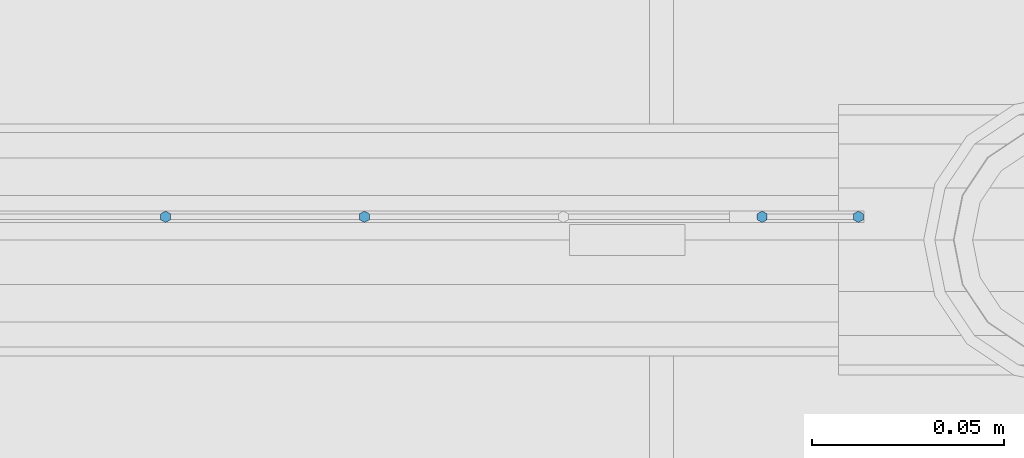
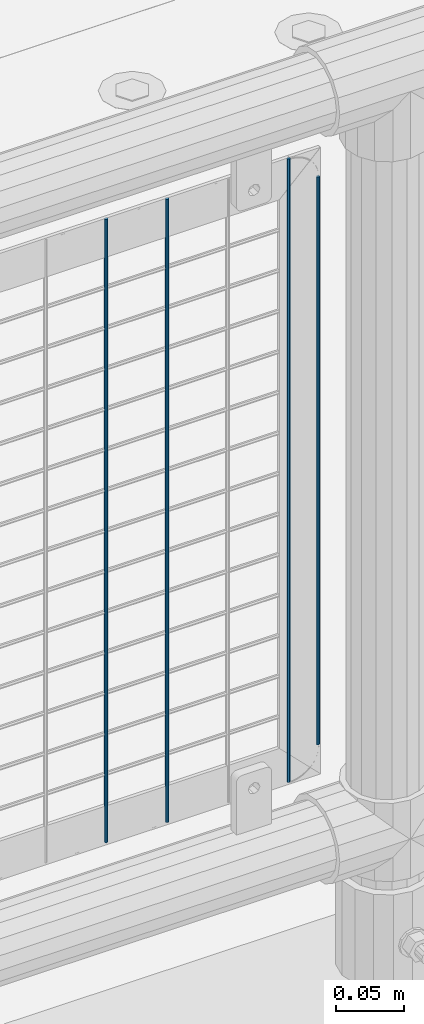
# One storey, part 80 of 219: 4 columns.
"""IFC2X3 building model written with IfcOpenShell, lengths in millimetres."""

from ifc_helpers import new_model, si_unit, frame, origin_with_axes, place, context, subcontext, project, spatial, faceted_brep, material, type_object, element, save


model = new_model("IFC2X3")

# Units and contexts
model_context = context("Model", 3, precision=1e-05, world=origin_with_axes())
body_context = subcontext(model_context, "Body", "Model", "MODEL_VIEW")
ifc_project = project(units=[si_unit("LENGTHUNIT", "METRE", prefix="MILLI"), si_unit("AREAUNIT", "SQUARE_METRE"), si_unit("VOLUMEUNIT", "CUBIC_METRE"), si_unit("MASSUNIT", "GRAM", prefix="KILO"), si_unit("TIMEUNIT", "SECOND"), si_unit("PLANEANGLEUNIT", "RADIAN"), si_unit("SOLIDANGLEUNIT", "STERADIAN"), si_unit("THERMODYNAMICTEMPERATUREUNIT", "DEGREE_CELSIUS"), si_unit("LUMINOUSINTENSITYUNIT", "LUMEN")], contexts=[model_context])

# Site, building, storey
site_placement = place(None, origin_with_axes())
site = spatial("IfcSite", under=ifc_project, at=site_placement, CompositionType="ELEMENT")
building_placement = place(site_placement, origin_with_axes())
building = spatial("IfcBuilding", under=site, at=building_placement, Name="Standard", CompositionType="ELEMENT")
storey_placement = place(building_placement, origin_with_axes())
storey = spatial("IfcBuildingStorey", under=building, at=storey_placement, Name="Undefined", CompositionType="ELEMENT", Elevation=0.0)

# Columns
ifc_material = material(Name="Misc_Undefined")
column_type = type_object("IfcColumnType", Name="D3", PredefinedType="NOTDEFINED")
for number, where, z_axis, x_axis in (
    (1, (7069.685, 31670.5, 353.02), (-1.0, 0.0, 0.0), (0.0, 0.0, 1.0)),
    (2, (7018.03, 31670.5, 353.02), (-1.0, 0.0, 0.0), (0.0, 0.0, 1.0)),
    (3, (7172.995, 31670.5, 353.02), (-1.0, 0.0, 0.0), (0.0, 0.0, 1.0)),
):
    element("IfcColumn", number, at=place(storey_placement, frame(where, z_axis=z_axis, x_axis=x_axis)), inside=storey, type_object=column_type, material=ifc_material, ObjectType="D3", context=body_context, shape_type="Brep", body=[
        faceted_brep([(0.0, -1.5, -5.6843418860808e-14), (0.0, -0.75, -1.29903810567669), (560.0, -0.75, -1.29903810567703), (560.0, -1.5, 0.0), (0.0, 0.75, -1.29903810567669), (560.0, 0.75, -1.29903810567703), (0.0, 1.5, -5.6843418860808e-14), (560.0, 1.5, 0.0), (0.0, 0.75, 1.29903810567669), (560.0, 0.75, 1.29903810567703), (0.0, -0.75, 1.29903810567669), (560.0, -0.75, 1.29903810567703)], [[[0, 1, 2, 3]], [[1, 4, 5, 2]], [[4, 6, 7, 5]], [[6, 8, 9, 7]], [[8, 10, 11, 9]], [[10, 0, 3, 11]], [[5, 7, 9, 11, 3, 2]], [[10, 8, 6, 4, 1, 0]]]),
    ])
column_placement = place(storey_placement, frame((7198.0, 31670.5, 378.02), z_axis=(-1.0, 0.0, 0.0), x_axis=(0.0, 0.0, 1.0)))
element("IfcColumn", 4, at=column_placement, inside=storey, type_object=column_type, material=ifc_material, ObjectType="D3", context=body_context, shape_type="Brep", body=[
    faceted_brep([(0.0, -1.5, -5.6843418860808e-14), (0.0, -0.75, -1.29903810567669), (510.0, -0.75, -1.29903810567703), (510.0, -1.5, 0.0), (0.0, 0.75, -1.29903810567669), (510.0, 0.75, -1.29903810567703), (0.0, 1.5, -5.6843418860808e-14), (510.0, 1.5, 0.0), (0.0, 0.75, 1.29903810567669), (510.0, 0.75, 1.29903810567703), (0.0, -0.75, 1.29903810567669), (510.0, -0.75, 1.29903810567703)], [[[0, 1, 2, 3]], [[1, 4, 5, 2]], [[4, 6, 7, 5]], [[6, 8, 9, 7]], [[8, 10, 11, 9]], [[10, 0, 3, 11]], [[5, 7, 9, 11, 3, 2]], [[10, 8, 6, 4, 1, 0]]]),
])

save(model, "model.ifc")
